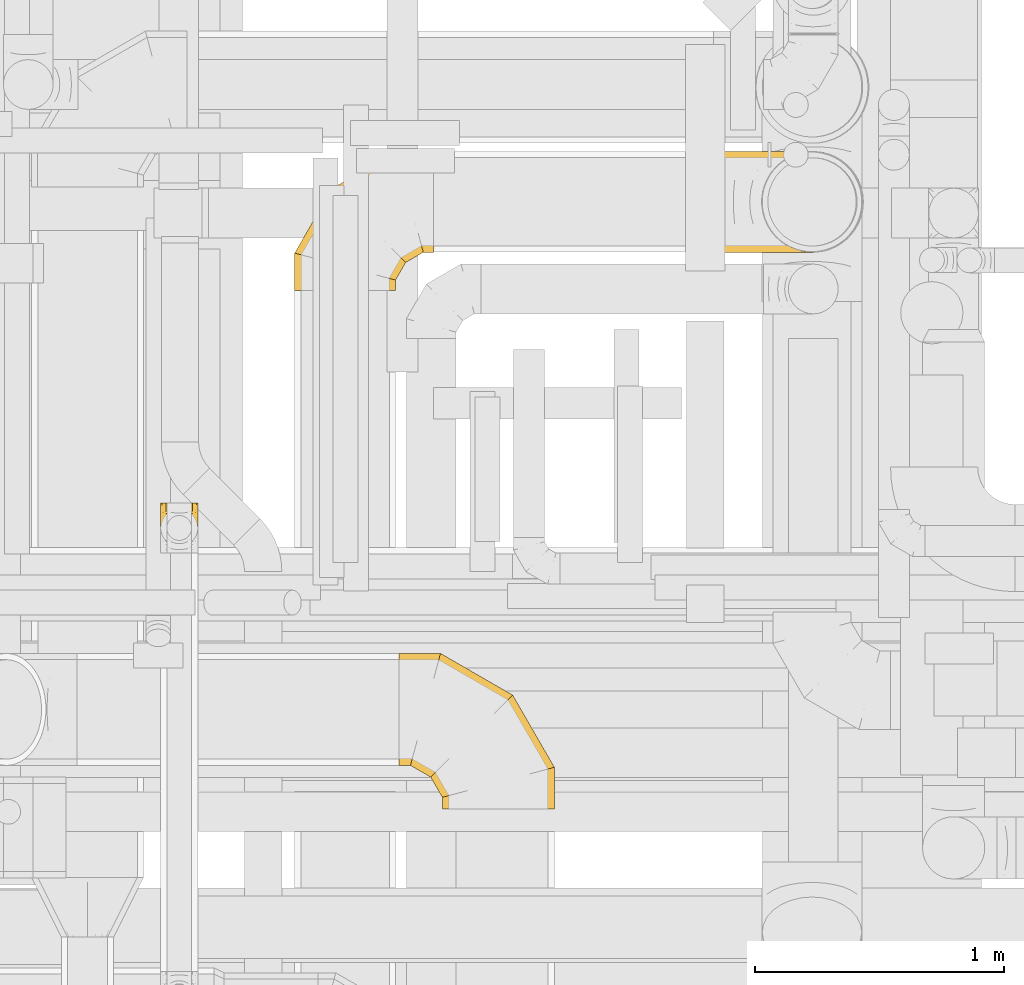
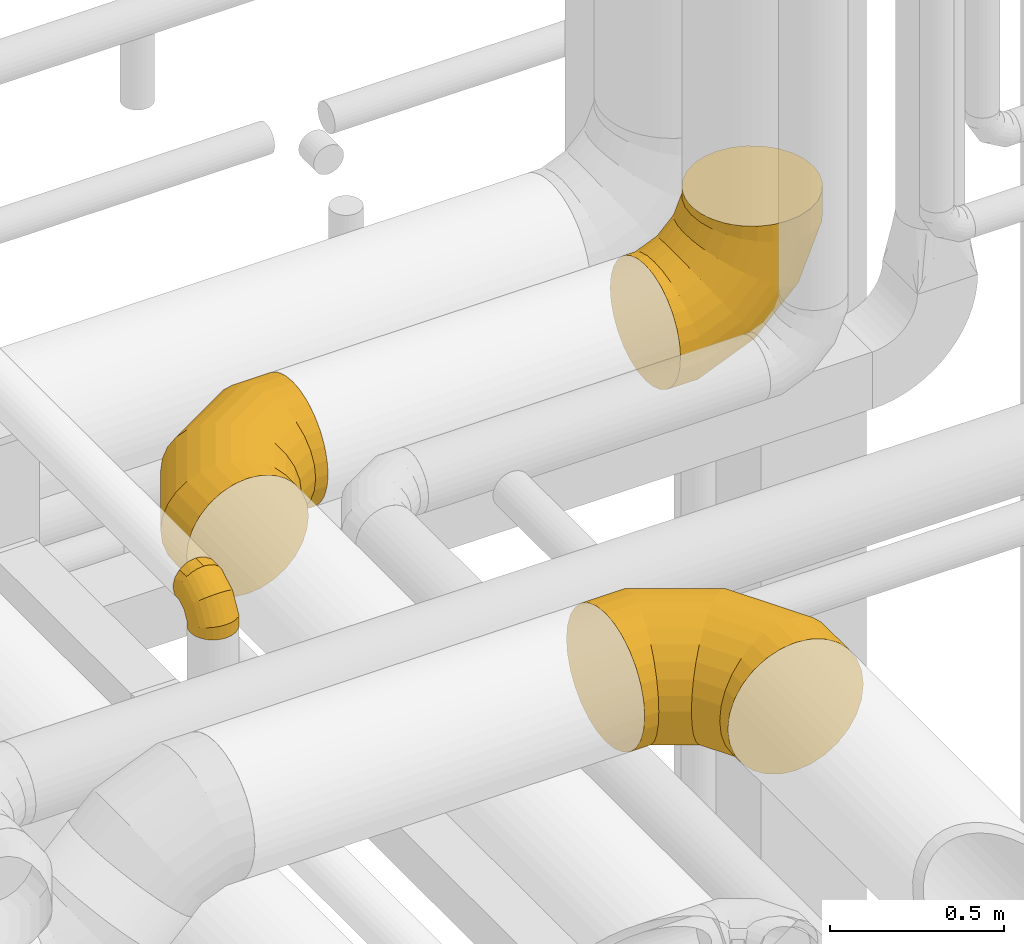
# One storey, part 19 of 337: 4 coverings.
"""IFC2X3 building model written with IfcOpenShell, lengths in millimetres."""

from ifc_helpers import new_model, entity, si_unit, converted_unit, derived_unit, direction, frame, origin, place, context, subcontext, project, spatial, faceted_brep, element, save


model = new_model("IFC2X3")

# Units and contexts
model_context = context("Model", 3, precision=0.01, world=origin(), true_north=direction((6.12303176911189e-17, 1.0)))
body_context = subcontext(model_context, "Body", "Model", "MODEL_VIEW")
ifc_project = project(units=[si_unit("LENGTHUNIT", "METRE", prefix="MILLI"), si_unit("AREAUNIT", "SQUARE_METRE"), si_unit("VOLUMEUNIT", "CUBIC_METRE"), converted_unit("PLANEANGLEUNIT", "DEGREE", entity("IfcRatioMeasure", 0.0174532925199433), si_unit("PLANEANGLEUNIT", "RADIAN"), dimensions=[0, 0, 0, 0, 0, 0, 0]), si_unit("MASSUNIT", "GRAM", prefix="KILO"), derived_unit("MASSDENSITYUNIT", [(si_unit("MASSUNIT", "GRAM", prefix="KILO"), 1), (si_unit("LENGTHUNIT", "METRE"), -3)]), derived_unit("MOMENTOFINERTIAUNIT", [(si_unit("LENGTHUNIT", "METRE"), 4)]), si_unit("TIMEUNIT", "SECOND"), si_unit("FREQUENCYUNIT", "HERTZ"), si_unit("THERMODYNAMICTEMPERATUREUNIT", "DEGREE_CELSIUS"), derived_unit("THERMALTRANSMITTANCEUNIT", [(si_unit("MASSUNIT", "GRAM", prefix="KILO"), 1), (si_unit("THERMODYNAMICTEMPERATUREUNIT", "KELVIN"), -1), (si_unit("TIMEUNIT", "SECOND"), -3)]), derived_unit("VOLUMETRICFLOWRATEUNIT", [(si_unit("LENGTHUNIT", "METRE"), 3), (si_unit("TIMEUNIT", "SECOND"), -1)]), derived_unit("MASSFLOWRATEUNIT", [(si_unit("MASSUNIT", "GRAM", prefix="KILO"), 1), (si_unit("TIMEUNIT", "SECOND"), -1)]), derived_unit("ROTATIONALFREQUENCYUNIT", [(si_unit("TIMEUNIT", "SECOND"), -1)]), si_unit("ELECTRICCURRENTUNIT", "AMPERE"), si_unit("ELECTRICVOLTAGEUNIT", "VOLT"), si_unit("POWERUNIT", "WATT"), si_unit("FORCEUNIT", "NEWTON", prefix="KILO"), si_unit("ILLUMINANCEUNIT", "LUX"), si_unit("LUMINOUSFLUXUNIT", "LUMEN"), si_unit("LUMINOUSINTENSITYUNIT", "CANDELA"), derived_unit("USERDEFINED", [(si_unit("MASSUNIT", "GRAM", prefix="KILO"), -1), (si_unit("LENGTHUNIT", "METRE"), -2), (si_unit("TIMEUNIT", "SECOND"), 3), (si_unit("LUMINOUSFLUXUNIT", "LUMEN"), 1)]), derived_unit("LINEARVELOCITYUNIT", [(si_unit("LENGTHUNIT", "METRE"), 1), (si_unit("TIMEUNIT", "SECOND"), -1)]), si_unit("PRESSUREUNIT", "PASCAL"), derived_unit("USERDEFINED", [(si_unit("LENGTHUNIT", "METRE"), -2), (si_unit("MASSUNIT", "GRAM", prefix="KILO"), 1), (si_unit("TIMEUNIT", "SECOND"), -2)]), derived_unit("LINEARFORCEUNIT", [(si_unit("MASSUNIT", "GRAM", prefix="KILO"), 1), (si_unit("LENGTHUNIT", "METRE"), 1), (si_unit("TIMEUNIT", "SECOND"), -2), (si_unit("LENGTHUNIT", "METRE"), -1)]), derived_unit("PLANARFORCEUNIT", [(si_unit("MASSUNIT", "GRAM", prefix="KILO"), 1), (si_unit("LENGTHUNIT", "METRE"), 1), (si_unit("TIMEUNIT", "SECOND"), -2), (si_unit("LENGTHUNIT", "METRE"), -2)])], contexts=[model_context])

# Site, building, storey
site_placement = place(None, origin())
site = spatial("IfcSite", under=ifc_project, at=site_placement, CompositionType="ELEMENT")
building_placement = place(site_placement, origin())
building = spatial("IfcBuilding", under=site, at=building_placement, CompositionType="ELEMENT")
storey_placement = place(building_placement, origin())
storey = spatial("IfcBuildingStorey", under=building, at=storey_placement, CompositionType="ELEMENT", Elevation=0.0)

# Coverings
covering_1_placement = place(storey_placement, frame((65898.97, 9350.0, 3273.4)))
element("IfcCovering", 1, at=covering_1_placement, inside=storey, PredefinedType="INSULATION", context=body_context, shape_type="Brep", body=[
    faceted_brep([(0.0, 400.0, 451.6), (0.0, 450.07, 445.95), (0.0, 497.62, 429.31), (0.0, 540.29, 402.51), (0.0, 575.91, 366.88), (0.0, 602.72, 324.22), (0.0, 619.36, 276.66), (0.0, 625.0, 226.6), (0.0, 619.36, 176.53), (0.0, 602.72, 128.97), (0.0, 575.91, 86.31), (0.0, 540.29, 50.68), (0.0, 497.62, 23.88), (0.0, 450.07, 7.24), (0.0, 400.0, 1.6), (0.0, 349.93, 7.24), (0.0, 302.38, 23.88), (0.0, 259.71, 50.68), (0.0, 224.09, 86.31), (0.0, 197.28, 128.97), (0.0, 180.64, 176.53), (0.0, 175.0, 226.6), (0.0, 180.64, 276.66), (0.0, 197.28, 324.22), (0.0, 224.09, 366.88), (0.0, 259.71, 402.51), (0.0, 302.38, 429.31), (0.0, 349.93, 445.95), (575.91, 0.0, 86.31), (602.72, 0.0, 128.97), (619.36, 0.0, 176.53), (625.0, 0.0, 226.6), (619.36, 0.0, 276.66), (602.72, 0.0, 324.22), (575.91, 0.0, 366.88), (540.29, 0.0, 402.51), (497.62, 0.0, 429.31), (450.07, 0.0, 445.95), (400.0, 0.0, 451.6), (349.93, 0.0, 445.95), (302.38, 0.0, 429.31), (259.71, 0.0, 402.51), (224.09, 0.0, 366.88), (197.28, 0.0, 324.22), (180.64, 0.0, 276.66), (175.0, 0.0, 226.6), (180.64, 0.0, 176.53), (197.28, 0.0, 128.97), (224.09, 0.0, 86.31), (259.71, 0.0, 50.68), (302.38, 0.0, 23.88), (349.93, 0.0, 7.24), (400.0, 0.0, 1.6), (450.07, 0.0, 7.24), (497.62, 0.0, 23.88), (540.29, 0.0, 50.68), (625.0, 167.47, 226.6), (619.36, 165.96, 276.66), (602.72, 161.5, 324.22), (575.91, 154.32, 366.88), (540.29, 144.77, 402.51), (497.62, 133.34, 429.31), (450.07, 120.6, 445.95), (400.0, 107.18, 451.6), (349.93, 93.76, 445.95), (302.38, 81.02, 429.31), (259.71, 69.59, 402.51), (224.09, 60.04, 366.88), (197.28, 52.86, 324.22), (180.64, 48.4, 276.66), (175.0, 46.89, 226.6), (180.64, 48.4, 176.53), (197.28, 52.86, 128.97), (224.09, 60.04, 86.31), (259.71, 69.59, 50.68), (302.38, 81.02, 23.88), (349.93, 93.76, 7.24), (400.0, 107.18, 1.6), (450.07, 120.6, 7.24), (497.62, 133.34, 23.88), (540.29, 144.77, 50.68), (575.91, 154.32, 86.31), (602.72, 161.5, 128.97), (619.36, 165.96, 176.53), (457.53, 457.53, 226.6), (453.4, 453.4, 276.66), (441.22, 441.22, 324.22), (421.6, 421.6, 366.88), (395.52, 395.52, 402.51), (364.29, 364.29, 429.31), (329.47, 329.47, 445.95), (292.82, 292.82, 451.6), (256.17, 256.17, 445.95), (221.35, 221.35, 429.31), (190.12, 190.12, 402.51), (164.04, 164.04, 366.88), (144.42, 144.42, 324.22), (132.24, 132.24, 276.66), (128.11, 128.11, 226.6), (132.24, 132.24, 176.53), (144.42, 144.42, 128.97), (164.04, 164.04, 86.31), (190.12, 190.12, 50.68), (221.35, 221.35, 23.88), (256.17, 256.17, 7.24), (292.82, 292.82, 1.6), (329.47, 329.47, 7.24), (364.29, 364.29, 23.88), (395.52, 395.52, 50.68), (421.6, 421.6, 86.31), (441.22, 441.22, 128.97), (453.4, 453.4, 176.53), (167.47, 625.0, 226.6), (165.96, 619.36, 276.66), (161.5, 602.72, 324.22), (154.32, 575.91, 366.88), (144.77, 540.29, 402.51), (133.34, 497.62, 429.31), (120.6, 450.07, 445.95), (107.18, 400.0, 451.6), (93.76, 349.93, 445.95), (81.02, 302.38, 429.31), (69.59, 259.71, 402.51), (60.04, 224.09, 366.88), (52.86, 197.28, 324.22), (48.4, 180.64, 276.66), (46.89, 175.0, 226.6), (48.4, 180.64, 176.53), (52.86, 197.28, 128.97), (60.04, 224.09, 86.31), (69.59, 259.71, 50.68), (81.02, 302.38, 23.88), (93.76, 349.93, 7.24), (107.18, 400.0, 1.6), (120.6, 450.07, 7.24), (133.34, 497.62, 23.88), (144.77, 540.29, 50.68), (154.32, 575.91, 86.31), (161.5, 602.72, 128.97), (165.96, 619.36, 176.53)], [[[0, 1, 2, 3, 4, 5, 6, 7, 8, 9, 10, 11, 12, 13, 14, 15, 16, 17, 18, 19, 20, 21, 22, 23, 24, 25, 26, 27]], [[28, 29, 30, 31, 32, 33, 34, 35, 36, 37, 38, 39, 40, 41, 42, 43, 44, 45, 46, 47, 48, 49, 50, 51, 52, 53, 54, 55]], [[31, 56, 57, 32]], [[32, 57, 58, 33]], [[33, 58, 59, 34]], [[59, 60, 35, 34]], [[35, 60, 61, 36]], [[36, 61, 62, 37]], [[37, 62, 63, 38]], [[63, 64, 39, 38]], [[65, 66, 41, 40]], [[64, 65, 40, 39]], [[66, 67, 42, 41]], [[67, 68, 43, 42]], [[69, 70, 45, 44]], [[68, 69, 44, 43]], [[70, 71, 46, 45]], [[72, 73, 48, 47]], [[71, 72, 47, 46]], [[73, 74, 49, 48]], [[74, 75, 50, 49]], [[76, 77, 52, 51]], [[75, 76, 51, 50]], [[53, 52, 77, 78]], [[78, 79, 54, 53]], [[80, 55, 54, 79]], [[80, 81, 28, 55]], [[29, 28, 81, 82]], [[82, 83, 30, 29]], [[56, 31, 30, 83]], [[57, 56, 84, 85]], [[57, 85, 86, 58]], [[59, 58, 86, 87]], [[87, 88, 60, 59]], [[61, 60, 88, 89]], [[62, 61, 89, 90]], [[63, 62, 90, 91]], [[91, 92, 64, 63]], [[93, 94, 66, 65]], [[92, 93, 65, 64]], [[94, 95, 67, 66]], [[95, 96, 68, 67]], [[97, 98, 70, 69]], [[96, 97, 69, 68]], [[98, 99, 71, 70]], [[100, 101, 73, 72]], [[99, 100, 72, 71]], [[101, 102, 74, 73]], [[102, 103, 75, 74]], [[104, 105, 77, 76]], [[103, 104, 76, 75]], [[78, 77, 105, 106]], [[106, 107, 79, 78]], [[108, 80, 79, 107]], [[108, 109, 81, 80]], [[82, 81, 109, 110]], [[110, 111, 83, 82]], [[84, 56, 83, 111]], [[85, 84, 112, 113]], [[85, 113, 114, 86]], [[87, 86, 114, 115]], [[115, 116, 88, 87]], [[89, 88, 116, 117]], [[90, 89, 117, 118]], [[91, 90, 118, 119]], [[119, 120, 92, 91]], [[121, 122, 94, 93]], [[120, 121, 93, 92]], [[122, 123, 95, 94]], [[123, 124, 96, 95]], [[125, 126, 98, 97]], [[124, 125, 97, 96]], [[126, 127, 99, 98]], [[128, 129, 101, 100]], [[127, 128, 100, 99]], [[129, 130, 102, 101]], [[130, 131, 103, 102]], [[132, 133, 105, 104]], [[131, 132, 104, 103]], [[106, 105, 133, 134]], [[134, 135, 107, 106]], [[136, 108, 107, 135]], [[136, 137, 109, 108]], [[110, 109, 137, 138]], [[138, 139, 111, 110]], [[112, 84, 111, 139]], [[113, 112, 7, 6]], [[5, 4, 115, 114]], [[114, 113, 6, 5]], [[4, 3, 116, 115]], [[117, 116, 3, 2]], [[118, 117, 2, 1]], [[119, 118, 1, 0]], [[120, 119, 0, 27]], [[26, 25, 122, 121]], [[121, 120, 27, 26]], [[25, 24, 123, 122]], [[124, 123, 24, 23]], [[125, 124, 23, 22]], [[126, 125, 22, 21]], [[21, 20, 127, 126]], [[20, 19, 128, 127]], [[128, 19, 18, 129]], [[18, 17, 130, 129]], [[130, 17, 16, 131]], [[131, 16, 15, 132]], [[132, 15, 14, 133]], [[133, 14, 13, 134]], [[134, 13, 12, 135]], [[135, 12, 11, 136]], [[11, 10, 137, 136]], [[137, 10, 9, 138]], [[138, 9, 8, 139]], [[139, 8, 7, 112]]]),
])
covering_2_placement = place(storey_placement, frame((65479.14, 11434.15, 2845.9)))
element("IfcCovering", 2, at=covering_2_placement, inside=storey, PredefinedType="INSULATION", context=body_context, shape_type="Brep", body=[
    faceted_brep([(159.03, 0.0, 401.52), (116.23, 0.0, 386.54), (77.84, 0.0, 362.42), (45.77, 0.0, 330.35), (21.65, 0.0, 291.96), (6.67, 0.0, 249.16), (1.6, 0.0, 204.1), (6.67, 0.0, 159.03), (21.65, 0.0, 116.23), (45.77, 0.0, 77.84), (77.84, 0.0, 45.77), (116.23, 0.0, 21.65), (159.03, 0.0, 6.67), (204.1, 0.0, 1.6), (249.16, 0.0, 6.67), (291.96, 0.0, 21.65), (330.35, 0.0, 45.77), (362.42, 0.0, 77.84), (386.54, 0.0, 116.23), (401.52, 0.0, 159.03), (406.6, 0.0, 204.1), (401.52, 0.0, 249.16), (386.54, 0.0, 291.96), (362.42, 0.0, 330.35), (330.35, 0.0, 362.42), (291.96, 0.0, 386.54), (249.16, 0.0, 401.52), (204.1, 0.0, 406.6), (559.1, 513.32, 77.84), (559.1, 537.45, 116.23), (559.1, 552.42, 159.03), (559.1, 557.5, 204.1), (559.1, 552.42, 249.16), (559.1, 537.45, 291.96), (559.1, 513.32, 330.35), (559.1, 481.26, 362.42), (559.1, 442.86, 386.54), (559.1, 400.06, 401.52), (559.1, 355.0, 406.6), (559.1, 309.94, 401.52), (559.1, 267.14, 386.54), (559.1, 228.74, 362.42), (559.1, 196.68, 330.35), (559.1, 172.55, 291.96), (559.1, 157.58, 249.16), (559.1, 152.5, 204.1), (559.1, 157.58, 159.03), (559.1, 172.55, 116.23), (559.1, 196.68, 77.84), (559.1, 228.74, 45.77), (559.1, 267.14, 21.65), (559.1, 309.94, 6.67), (559.1, 355.0, 1.6), (559.1, 400.06, 6.67), (559.1, 442.86, 21.65), (559.1, 481.26, 45.77), (409.71, 557.5, 204.1), (411.07, 552.42, 249.16), (415.09, 537.45, 291.96), (421.55, 513.32, 330.35), (430.14, 481.26, 362.42), (440.43, 442.86, 386.54), (451.9, 400.06, 401.52), (463.97, 355.0, 406.6), (476.05, 309.94, 401.52), (487.52, 267.14, 386.54), (497.8, 228.74, 362.42), (506.4, 196.68, 330.35), (512.86, 172.55, 291.96), (516.87, 157.58, 249.16), (518.23, 152.5, 204.1), (516.87, 157.58, 159.03), (512.86, 172.55, 116.23), (506.4, 196.68, 77.84), (497.8, 228.74, 45.77), (487.52, 267.14, 21.65), (476.05, 309.94, 6.67), (463.97, 355.0, 1.6), (451.9, 400.06, 6.67), (440.43, 442.86, 21.65), (430.14, 481.26, 45.77), (421.55, 513.32, 77.84), (415.09, 537.45, 116.23), (411.07, 552.42, 159.03), (150.98, 408.12, 204.1), (154.69, 404.4, 249.16), (165.66, 393.44, 291.96), (183.32, 375.78, 330.35), (206.79, 352.3, 362.42), (234.9, 324.2, 386.54), (266.23, 292.86, 401.52), (299.22, 259.88, 406.6), (332.2, 226.89, 401.52), (363.54, 195.56, 386.54), (391.64, 167.45, 362.42), (415.12, 143.98, 330.35), (432.78, 126.32, 291.96), (443.74, 115.35, 249.16), (447.46, 111.64, 204.1), (443.74, 115.35, 159.03), (432.78, 126.32, 116.23), (415.12, 143.98, 77.84), (391.64, 167.45, 45.77), (363.54, 195.56, 21.65), (332.2, 226.89, 6.67), (299.22, 259.88, 1.6), (266.23, 292.86, 6.67), (234.9, 324.2, 21.65), (206.79, 352.3, 45.77), (183.32, 375.78, 77.84), (165.66, 393.44, 116.23), (154.69, 404.4, 159.03), (1.6, 149.38, 204.1), (6.67, 148.02, 249.16), (21.65, 144.01, 291.96), (45.77, 137.54, 330.35), (77.84, 128.95, 362.42), (116.23, 118.66, 386.54), (159.03, 107.2, 401.52), (204.1, 95.12, 406.6), (249.16, 83.05, 401.52), (291.96, 71.58, 386.54), (330.35, 61.29, 362.42), (362.42, 52.7, 330.35), (386.54, 46.24, 291.96), (401.52, 42.22, 249.16), (406.6, 40.86, 204.1), (401.52, 42.22, 159.03), (386.54, 46.24, 116.23), (362.42, 52.7, 77.84), (330.35, 61.29, 45.77), (291.96, 71.58, 21.65), (249.16, 83.05, 6.67), (204.1, 95.12, 1.6), (159.03, 107.2, 6.67), (116.23, 118.66, 21.65), (77.84, 128.95, 45.77), (45.77, 137.54, 77.84), (21.65, 144.01, 116.23), (6.67, 148.02, 159.03)], [[[0, 1, 2, 3, 4, 5, 6, 7, 8, 9, 10, 11, 12, 13, 14, 15, 16, 17, 18, 19, 20, 21, 22, 23, 24, 25, 26, 27]], [[28, 29, 30, 31, 32, 33, 34, 35, 36, 37, 38, 39, 40, 41, 42, 43, 44, 45, 46, 47, 48, 49, 50, 51, 52, 53, 54, 55]], [[31, 56, 57, 32]], [[32, 57, 58, 33]], [[33, 58, 59, 34]], [[59, 60, 35, 34]], [[35, 60, 61, 36]], [[36, 61, 62, 37]], [[37, 62, 63, 38]], [[63, 64, 39, 38]], [[65, 66, 41, 40]], [[64, 65, 40, 39]], [[66, 67, 42, 41]], [[67, 68, 43, 42]], [[69, 70, 45, 44]], [[68, 69, 44, 43]], [[70, 71, 46, 45]], [[72, 73, 48, 47]], [[71, 72, 47, 46]], [[73, 74, 49, 48]], [[74, 75, 50, 49]], [[76, 77, 52, 51]], [[75, 76, 51, 50]], [[53, 52, 77, 78]], [[78, 79, 54, 53]], [[80, 55, 54, 79]], [[80, 81, 28, 55]], [[29, 28, 81, 82]], [[82, 83, 30, 29]], [[56, 31, 30, 83]], [[57, 56, 84, 85]], [[57, 85, 86, 58]], [[59, 58, 86, 87]], [[87, 88, 60, 59]], [[61, 60, 88, 89]], [[62, 61, 89, 90]], [[63, 62, 90, 91]], [[91, 92, 64, 63]], [[93, 94, 66, 65]], [[92, 93, 65, 64]], [[94, 95, 67, 66]], [[95, 96, 68, 67]], [[97, 98, 70, 69]], [[96, 97, 69, 68]], [[98, 99, 71, 70]], [[100, 101, 73, 72]], [[99, 100, 72, 71]], [[101, 102, 74, 73]], [[102, 103, 75, 74]], [[104, 105, 77, 76]], [[103, 104, 76, 75]], [[78, 77, 105, 106]], [[106, 107, 79, 78]], [[108, 80, 79, 107]], [[108, 109, 81, 80]], [[82, 81, 109, 110]], [[110, 111, 83, 82]], [[84, 56, 83, 111]], [[85, 84, 112, 113]], [[85, 113, 114, 86]], [[87, 86, 114, 115]], [[115, 116, 88, 87]], [[89, 88, 116, 117]], [[90, 89, 117, 118]], [[91, 90, 118, 119]], [[119, 120, 92, 91]], [[121, 122, 94, 93]], [[120, 121, 93, 92]], [[122, 123, 95, 94]], [[123, 124, 96, 95]], [[125, 126, 98, 97]], [[124, 125, 97, 96]], [[126, 127, 99, 98]], [[128, 129, 101, 100]], [[127, 128, 100, 99]], [[129, 130, 102, 101]], [[130, 131, 103, 102]], [[132, 133, 105, 104]], [[131, 132, 104, 103]], [[106, 105, 133, 134]], [[134, 135, 107, 106]], [[136, 108, 107, 135]], [[136, 137, 109, 108]], [[110, 109, 137, 138]], [[138, 139, 111, 110]], [[112, 84, 111, 139]], [[113, 112, 6, 5]], [[114, 113, 5, 4]], [[115, 114, 4, 3]], [[3, 2, 116, 115]], [[117, 116, 2, 1]], [[118, 117, 1, 0]], [[119, 118, 0, 27]], [[120, 119, 27, 26]], [[25, 24, 122, 121]], [[121, 120, 26, 25]], [[24, 23, 123, 122]], [[124, 123, 23, 22]], [[125, 124, 22, 21]], [[126, 125, 21, 20]], [[126, 20, 19, 127]], [[18, 17, 129, 128]], [[127, 19, 18, 128]], [[17, 16, 130, 129]], [[130, 16, 15, 131]], [[131, 15, 14, 132]], [[132, 14, 13, 133]], [[133, 13, 12, 134]], [[134, 12, 11, 135]], [[135, 11, 10, 136]], [[10, 9, 137, 136]], [[137, 9, 8, 138]], [[138, 8, 7, 139]], [[139, 7, 6, 112]]]),
])
covering_3_placement = place(storey_placement, frame((64940.15, 10402.54, 3550.0)))
element("IfcCovering", 3, at=covering_3_placement, inside=storey, PredefinedType="INSULATION", context=body_context, shape_type="Brep", body=[
    faceted_brep([(47.89, 176.6, 169.29), (62.24, 176.6, 172.15), (76.6, 176.6, 175.0), (90.95, 176.6, 172.15), (105.3, 176.6, 169.29), (117.46, 176.6, 161.16), (129.63, 176.6, 153.03), (137.76, 176.6, 140.87), (145.89, 176.6, 128.7), (148.74, 176.6, 114.35), (151.6, 176.6, 100.0), (148.74, 176.6, 85.65), (145.89, 176.6, 71.3), (137.76, 176.6, 59.13), (129.63, 176.6, 46.97), (117.46, 176.6, 38.84), (105.3, 176.6, 30.71), (90.95, 176.6, 27.85), (83.77, 176.6, 26.43), (76.6, 176.6, 25.0), (69.42, 176.6, 26.43), (62.24, 176.6, 27.85), (47.89, 176.6, 30.71), (35.73, 176.6, 38.84), (23.56, 176.6, 46.97), (15.43, 176.6, 59.13), (7.3, 176.6, 71.3), (4.45, 176.6, 85.65), (1.6, 176.6, 100.0), (4.45, 176.6, 114.35), (7.3, 176.6, 128.7), (15.43, 176.6, 140.87), (23.56, 176.6, 153.03), (35.73, 176.6, 161.16), (96.01, 4.15, 0.0), (76.6, 1.6, 0.0), (57.18, 4.15, 0.0), (39.1, 11.64, 0.0), (23.56, 23.56, 0.0), (11.64, 39.1, 0.0), (4.15, 57.18, 0.0), (1.6, 76.6, 0.0), (4.15, 96.01, 0.0), (11.64, 114.1, 0.0), (23.56, 129.63, 0.0), (39.1, 141.55, 0.0), (57.18, 149.04, 0.0), (76.6, 151.6, 0.0), (96.01, 149.04, 0.0), (114.1, 141.55, 0.0), (129.63, 129.63, 0.0), (141.55, 114.1, 0.0), (149.04, 96.01, 0.0), (151.6, 76.6, 0.0), (149.04, 57.18, 0.0), (141.55, 39.1, 0.0), (129.63, 23.56, 0.0), (114.1, 11.64, 0.0), (76.6, 1.6, 46.89), (57.18, 4.15, 46.21), (39.1, 11.64, 44.2), (23.56, 23.56, 41.01), (11.64, 39.1, 36.84), (4.15, 57.18, 32.0), (1.6, 76.6, 26.79), (4.15, 96.01, 21.59), (11.64, 114.1, 16.75), (23.56, 129.63, 12.58), (39.1, 141.55, 9.39), (57.18, 149.04, 7.38), (76.6, 151.6, 6.7), (96.01, 149.04, 7.38), (114.1, 141.55, 9.39), (129.63, 129.63, 12.58), (149.04, 96.01, 21.59), (151.6, 76.6, 26.79), (141.55, 114.1, 16.75), (149.04, 57.18, 32.0), (141.55, 39.1, 36.84), (129.63, 23.56, 41.01), (114.1, 11.64, 44.2), (96.01, 4.15, 46.21), (76.6, 48.49, 128.11), (57.18, 50.36, 126.24), (39.1, 55.84, 120.75), (23.56, 64.57, 112.03), (11.64, 75.94, 100.66), (4.15, 89.18, 87.42), (1.6, 103.39, 73.21), (4.15, 117.6, 58.99), (11.64, 130.84, 45.75), (23.56, 142.21, 34.38), (39.1, 150.94, 25.66), (57.18, 156.42, 20.17), (76.6, 158.29, 18.3), (96.01, 156.42, 20.17), (114.1, 150.94, 25.66), (129.63, 142.21, 34.38), (149.04, 117.6, 58.99), (151.6, 103.39, 73.21), (141.55, 130.84, 45.75), (149.04, 89.18, 87.42), (141.55, 75.94, 100.66), (129.63, 64.57, 112.03), (114.1, 55.84, 120.75), (96.01, 50.36, 126.24), (76.6, 129.7, 175.0), (57.18, 130.39, 172.44), (39.1, 132.4, 164.95), (23.56, 135.59, 153.03), (11.64, 139.75, 137.5), (4.15, 144.6, 119.41), (1.6, 149.8, 100.0), (4.15, 155.0, 80.59), (11.64, 159.85, 62.5), (23.56, 164.01, 46.97), (39.1, 167.2, 35.05), (48.14, 168.21, 31.3), (57.18, 169.21, 27.56), (66.89, 169.55, 26.28), (76.6, 169.9, 25.0), (96.01, 169.21, 27.56), (105.05, 168.21, 31.3), (114.1, 167.2, 35.05), (86.3, 169.55, 26.28), (129.63, 164.01, 46.97), (149.04, 155.0, 80.59), (151.6, 149.8, 100.0), (141.55, 159.85, 62.5), (149.04, 144.6, 119.41), (141.55, 139.75, 137.5), (129.63, 135.59, 153.03), (114.1, 132.4, 164.95), (96.01, 130.39, 172.44)], [[[0, 1, 2, 3, 4, 5, 6, 7, 8, 9, 10, 11, 12, 13, 14, 15, 16, 17, 18, 19, 20, 21, 22, 23, 24, 25, 26, 27, 28, 29, 30, 31, 32, 33]], [[34, 35, 36, 37, 38, 39, 40, 41, 42, 43, 44, 45, 46, 47, 48, 49, 50, 51, 52, 53, 54, 55, 56, 57]], [[35, 58, 59, 36]], [[36, 59, 60, 37]], [[37, 60, 61, 38]], [[39, 62, 63, 40]], [[40, 63, 64, 41]], [[38, 61, 62, 39]], [[65, 66, 43, 42]], [[64, 65, 42, 41]], [[67, 44, 43, 66]], [[68, 69, 46, 45]], [[68, 45, 44, 67]], [[70, 47, 46, 69]], [[71, 72, 49, 48]], [[70, 71, 48, 47]], [[50, 49, 72, 73]], [[74, 75, 53, 52]], [[76, 74, 52, 51]], [[73, 76, 51, 50]], [[55, 54, 77, 78]], [[56, 55, 78, 79]], [[53, 75, 77, 54]], [[34, 57, 80, 81]], [[35, 34, 81, 58]], [[79, 80, 57, 56]], [[58, 82, 83, 59]], [[60, 59, 83, 84]], [[84, 85, 61, 60]], [[62, 61, 85, 86]], [[63, 62, 86, 87]], [[64, 63, 87, 88]], [[89, 90, 66, 65]], [[88, 89, 65, 64]], [[67, 66, 90, 91]], [[92, 93, 69, 68]], [[91, 92, 68, 67]], [[70, 69, 93, 94]], [[95, 96, 72, 71]], [[94, 95, 71, 70]], [[73, 72, 96, 97]], [[98, 99, 75, 74]], [[100, 98, 74, 76]], [[97, 100, 76, 73]], [[77, 75, 99, 101]], [[78, 77, 101, 102]], [[79, 78, 102, 103]], [[81, 80, 104, 105]], [[58, 81, 105, 82]], [[103, 104, 80, 79]], [[82, 106, 107, 83]], [[84, 83, 107, 108]], [[108, 109, 85, 84]], [[86, 85, 109, 110]], [[87, 86, 110, 111]], [[88, 87, 111, 112]], [[113, 114, 90, 89]], [[112, 113, 89, 88]], [[91, 90, 114, 115]], [[93, 92, 116, 117, 118]], [[115, 116, 92, 91]], [[94, 93, 118, 119, 120]], [[95, 121, 122, 123, 96]], [[94, 120, 124, 121, 95]], [[97, 96, 123, 125]], [[126, 127, 99, 98]], [[128, 126, 98, 100]], [[125, 128, 100, 97]], [[101, 99, 127, 129]], [[102, 101, 129, 130]], [[103, 102, 130, 131]], [[105, 104, 132, 133]], [[82, 105, 133, 106]], [[131, 132, 104, 103]], [[106, 1, 107]], [[111, 30, 29]], [[1, 106, 2]], [[32, 109, 33]], [[108, 0, 33]], [[107, 0, 108]], [[31, 30, 110]], [[108, 33, 109]], [[31, 109, 32]], [[28, 112, 29]], [[1, 0, 107]], [[112, 111, 29]], [[110, 30, 111]], [[109, 31, 110]], [[113, 28, 27, 26]], [[24, 115, 25]], [[119, 21, 20]], [[114, 26, 25]], [[114, 113, 26]], [[120, 20, 19]], [[114, 25, 115]], [[28, 113, 112]], [[120, 119, 20]], [[21, 119, 118]], [[22, 118, 117, 116]], [[24, 23, 115]], [[115, 23, 116]], [[118, 22, 21]], [[116, 23, 22]], [[121, 17, 16]], [[15, 14, 125]], [[16, 123, 122, 121]], [[18, 17, 124]], [[18, 120, 19]], [[125, 123, 15]], [[13, 125, 14]], [[126, 12, 11, 10]], [[125, 13, 128]], [[120, 18, 124]], [[126, 128, 12]], [[126, 10, 127]], [[17, 121, 124]], [[123, 16, 15]], [[13, 12, 128]], [[127, 9, 129]], [[6, 131, 7]], [[130, 8, 7]], [[129, 8, 130]], [[5, 131, 6]], [[9, 8, 129]], [[130, 7, 131]], [[9, 127, 10]], [[133, 4, 3]], [[131, 5, 132]], [[2, 106, 3]], [[4, 133, 132]], [[106, 133, 3]], [[5, 4, 132]]]),
])
covering_4_placement = place(storey_placement, frame((67208.18, 11585.06, 2845.9)))
element("IfcCovering", 4, at=covering_4_placement, inside=storey, PredefinedType="INSULATION", context=body_context, shape_type="Brep", body=[
    faceted_brep([(400.06, 6.67, 559.15), (442.86, 21.65, 559.16), (481.26, 45.77, 559.16), (513.32, 77.84, 559.17), (537.45, 116.23, 559.17), (552.42, 159.03, 559.17), (557.5, 204.1, 559.17), (552.42, 249.16, 559.17), (537.45, 291.96, 559.17), (513.32, 330.35, 559.17), (481.26, 362.42, 559.16), (442.86, 386.54, 559.16), (400.06, 401.52, 559.15), (355.0, 406.6, 559.14), (309.94, 401.52, 559.14), (267.14, 386.54, 559.13), (228.74, 362.42, 559.13), (196.68, 330.35, 559.12), (172.55, 291.96, 559.12), (157.58, 249.16, 559.12), (152.5, 204.1, 559.12), (157.58, 159.03, 559.12), (172.55, 116.23, 559.12), (196.68, 77.84, 559.12), (228.74, 45.77, 559.13), (267.14, 21.65, 559.13), (309.94, 6.67, 559.14), (355.0, 1.6, 559.14), (0.0, 330.35, 45.77), (0.0, 291.96, 21.65), (0.0, 249.16, 6.67), (0.0, 204.1, 1.6), (0.0, 159.03, 6.67), (0.0, 116.23, 21.65), (0.0, 77.84, 45.77), (0.0, 45.77, 77.84), (0.0, 21.65, 116.23), (0.0, 6.67, 159.03), (0.0, 1.6, 204.1), (0.0, 6.67, 249.16), (0.0, 21.65, 291.96), (0.0, 45.77, 330.35), (0.0, 77.84, 362.42), (0.0, 116.23, 386.54), (0.0, 159.03, 401.52), (0.0, 204.1, 406.6), (0.0, 249.16, 401.52), (0.0, 291.96, 386.54), (0.0, 330.35, 362.42), (0.0, 362.42, 330.35), (0.0, 386.54, 291.96), (0.0, 401.52, 249.16), (0.0, 406.6, 204.1), (0.0, 401.52, 159.03), (0.0, 386.54, 116.23), (0.0, 362.42, 77.84), (110.9, 204.1, 1.6), (109.89, 159.03, 6.67), (106.91, 116.23, 21.65), (102.11, 77.84, 45.77), (95.74, 45.77, 77.84), (88.1, 21.65, 116.23), (79.58, 6.67, 159.03), (70.62, 1.6, 204.1), (61.66, 6.67, 249.16), (53.14, 21.65, 291.96), (45.5, 45.77, 330.35), (39.13, 77.84, 362.42), (34.33, 116.23, 386.54), (31.35, 159.03, 401.52), (30.34, 204.1, 406.6), (31.35, 249.16, 401.52), (34.33, 291.96, 386.54), (39.13, 330.35, 362.42), (45.5, 362.42, 330.35), (53.14, 386.54, 291.96), (61.66, 401.52, 249.16), (70.62, 406.6, 204.1), (79.58, 401.52, 159.03), (88.1, 386.54, 116.23), (95.74, 362.42, 77.84), (102.11, 330.35, 45.77), (106.91, 291.96, 21.65), (109.89, 249.16, 6.67), (315.82, 204.1, 86.48), (312.95, 159.03, 90.79), (304.46, 116.23, 103.48), (290.8, 77.84, 123.94), (272.63, 45.77, 151.12), (250.88, 21.65, 183.67), (226.63, 6.67, 219.95), (201.11, 1.6, 258.15), (175.58, 6.67, 296.35), (151.33, 21.65, 332.63), (129.58, 45.77, 365.18), (111.42, 77.84, 392.36), (97.75, 116.23, 412.82), (89.27, 159.03, 425.51), (86.39, 204.1, 429.82), (89.27, 249.16, 425.51), (97.75, 291.96, 412.82), (111.42, 330.35, 392.36), (129.58, 362.42, 365.18), (151.33, 386.54, 332.63), (175.58, 401.52, 296.35), (201.11, 406.6, 258.15), (226.63, 401.52, 219.95), (250.88, 386.54, 183.67), (272.63, 362.42, 151.12), (290.8, 330.35, 123.94), (304.46, 291.96, 103.48), (312.95, 249.16, 90.79), (472.65, 204.1, 243.34), (468.35, 159.03, 246.21), (455.65, 116.23, 254.69), (435.2, 77.84, 268.36), (408.01, 45.77, 286.52), (375.46, 21.65, 308.27), (339.18, 6.67, 332.51), (300.97, 1.6, 358.03), (262.77, 6.67, 383.55), (226.48, 21.65, 407.79), (193.93, 45.77, 429.54), (166.75, 77.84, 447.7), (146.29, 116.23, 461.36), (133.6, 159.03, 469.85), (129.29, 204.1, 472.72), (133.6, 249.16, 469.85), (146.29, 291.96, 461.36), (166.75, 330.35, 447.7), (193.93, 362.42, 429.54), (226.48, 386.54, 407.79), (262.77, 401.52, 383.55), (300.97, 406.6, 358.03), (339.18, 401.52, 332.51), (375.46, 386.54, 308.27), (408.01, 362.42, 286.52), (435.2, 330.35, 268.36), (455.65, 291.96, 254.69), (468.35, 249.16, 246.21), (557.52, 204.1, 448.27), (552.44, 159.03, 449.28), (537.46, 116.23, 452.25), (513.33, 77.84, 457.05), (481.27, 45.77, 463.42), (442.87, 21.65, 471.06), (400.07, 6.67, 479.57), (355.01, 1.6, 488.52), (309.95, 6.67, 497.48), (267.15, 21.65, 505.99), (228.75, 45.77, 513.62), (196.68, 77.84, 520.0), (172.56, 116.23, 524.79), (157.58, 159.03, 527.77), (152.5, 204.1, 528.78), (157.58, 249.16, 527.77), (172.56, 291.96, 524.79), (196.68, 330.35, 520.0), (228.75, 362.42, 513.62), (267.15, 386.54, 505.99), (309.95, 401.52, 497.48), (355.01, 406.6, 488.52), (400.07, 401.52, 479.57), (442.87, 386.54, 471.06), (481.27, 362.42, 463.42), (513.33, 330.35, 457.05), (537.46, 291.96, 452.25), (552.44, 249.16, 449.28)], [[[0, 1, 2, 3, 4, 5, 6, 7, 8, 9, 10, 11, 12, 13, 14, 15, 16, 17, 18, 19, 20, 21, 22, 23, 24, 25, 26, 27]], [[28, 29, 30, 31, 32, 33, 34, 35, 36, 37, 38, 39, 40, 41, 42, 43, 44, 45, 46, 47, 48, 49, 50, 51, 52, 53, 54, 55]], [[31, 56, 57, 32]], [[32, 57, 58, 33]], [[33, 58, 59, 34]], [[59, 60, 35, 34]], [[35, 60, 61, 36]], [[36, 61, 62, 37]], [[37, 62, 63, 38]], [[63, 64, 39, 38]], [[65, 66, 41, 40]], [[64, 65, 40, 39]], [[66, 67, 42, 41]], [[67, 68, 43, 42]], [[69, 70, 45, 44]], [[68, 69, 44, 43]], [[70, 71, 46, 45]], [[72, 73, 48, 47]], [[71, 72, 47, 46]], [[73, 74, 49, 48]], [[74, 75, 50, 49]], [[76, 77, 52, 51]], [[75, 76, 51, 50]], [[53, 52, 77, 78]], [[78, 79, 54, 53]], [[80, 55, 54, 79]], [[80, 81, 28, 55]], [[29, 28, 81, 82]], [[82, 83, 30, 29]], [[56, 31, 30, 83]], [[56, 84, 85, 57]], [[57, 85, 86, 58]], [[59, 58, 86, 87]], [[87, 88, 60, 59]], [[61, 60, 88, 89]], [[62, 61, 89, 90]], [[63, 62, 90, 91]], [[91, 92, 64, 63]], [[93, 94, 66, 65]], [[92, 93, 65, 64]], [[94, 95, 67, 66]], [[95, 96, 68, 67]], [[97, 98, 70, 69]], [[96, 97, 69, 68]], [[98, 99, 71, 70]], [[100, 101, 73, 72]], [[99, 100, 72, 71]], [[101, 102, 74, 73]], [[102, 103, 75, 74]], [[104, 105, 77, 76]], [[103, 104, 76, 75]], [[78, 77, 105, 106]], [[106, 107, 79, 78]], [[108, 80, 79, 107]], [[108, 109, 81, 80]], [[82, 81, 109, 110]], [[110, 111, 83, 82]], [[84, 56, 83, 111]], [[84, 112, 113, 85]], [[85, 113, 114, 86]], [[87, 86, 114, 115]], [[115, 116, 88, 87]], [[89, 88, 116, 117]], [[90, 89, 117, 118]], [[91, 90, 118, 119]], [[119, 120, 92, 91]], [[121, 122, 94, 93]], [[120, 121, 93, 92]], [[122, 123, 95, 94]], [[123, 124, 96, 95]], [[125, 126, 98, 97]], [[124, 125, 97, 96]], [[126, 127, 99, 98]], [[128, 129, 101, 100]], [[127, 128, 100, 99]], [[129, 130, 102, 101]], [[130, 131, 103, 102]], [[132, 133, 105, 104]], [[131, 132, 104, 103]], [[106, 105, 133, 134]], [[134, 135, 107, 106]], [[136, 108, 107, 135]], [[136, 137, 109, 108]], [[110, 109, 137, 138]], [[138, 139, 111, 110]], [[112, 84, 111, 139]], [[112, 140, 141, 113]], [[113, 141, 142, 114]], [[115, 114, 142, 143]], [[143, 144, 116, 115]], [[117, 116, 144, 145]], [[118, 117, 145, 146]], [[119, 118, 146, 147]], [[147, 148, 120, 119]], [[149, 150, 122, 121]], [[148, 149, 121, 120]], [[150, 151, 123, 122]], [[151, 152, 124, 123]], [[153, 154, 126, 125]], [[152, 153, 125, 124]], [[154, 155, 127, 126]], [[156, 157, 129, 128]], [[155, 156, 128, 127]], [[157, 158, 130, 129]], [[158, 159, 131, 130]], [[160, 161, 133, 132]], [[159, 160, 132, 131]], [[134, 133, 161, 162]], [[162, 163, 135, 134]], [[164, 136, 135, 163]], [[164, 165, 137, 136]], [[138, 137, 165, 166]], [[166, 167, 139, 138]], [[140, 112, 139, 167]], [[141, 140, 6, 5]], [[4, 3, 143, 142]], [[142, 141, 5, 4]], [[3, 2, 144, 143]], [[145, 144, 2, 1]], [[146, 145, 1, 0]], [[147, 146, 0, 27]], [[148, 147, 27, 26]], [[26, 25, 149, 148]], [[24, 150, 149, 25]], [[24, 23, 151, 150]], [[23, 22, 152, 151]], [[21, 20, 154, 153]], [[22, 21, 153, 152]], [[154, 20, 19, 155]], [[19, 18, 156, 155]], [[17, 157, 156, 18]], [[17, 16, 158, 157]], [[158, 16, 15, 159]], [[15, 14, 160, 159]], [[13, 161, 160, 14]], [[161, 13, 12, 162]], [[162, 12, 11, 163]], [[163, 11, 10, 164]], [[10, 9, 165, 164]], [[165, 9, 8, 166]], [[166, 8, 7, 167]], [[167, 7, 6, 140]]]),
])

save(model, "model.ifc")
